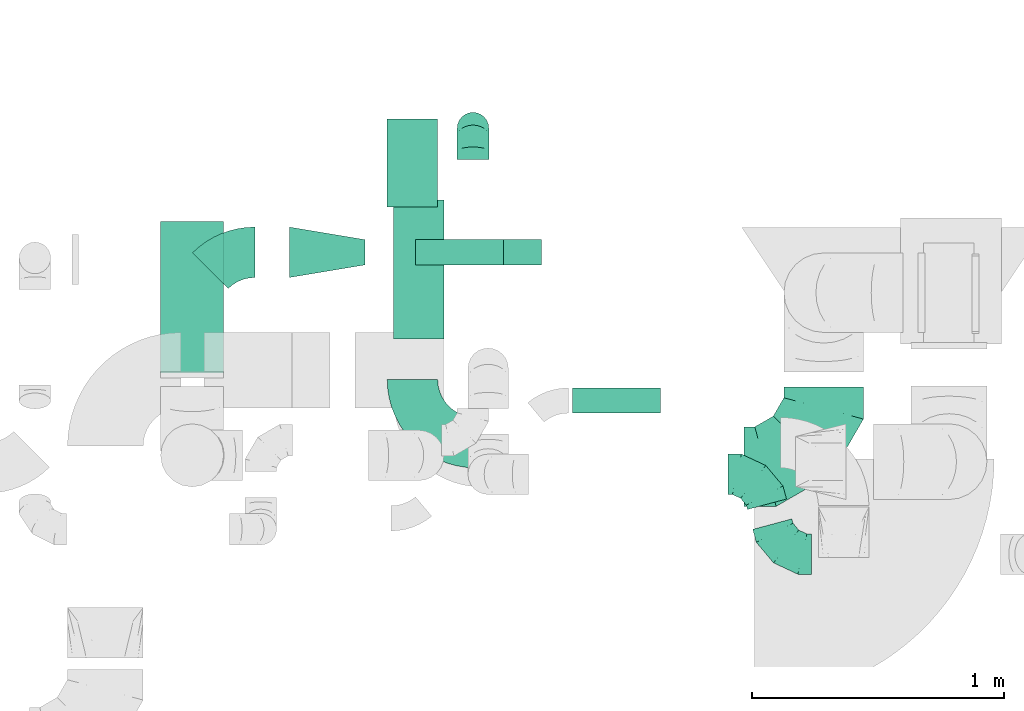
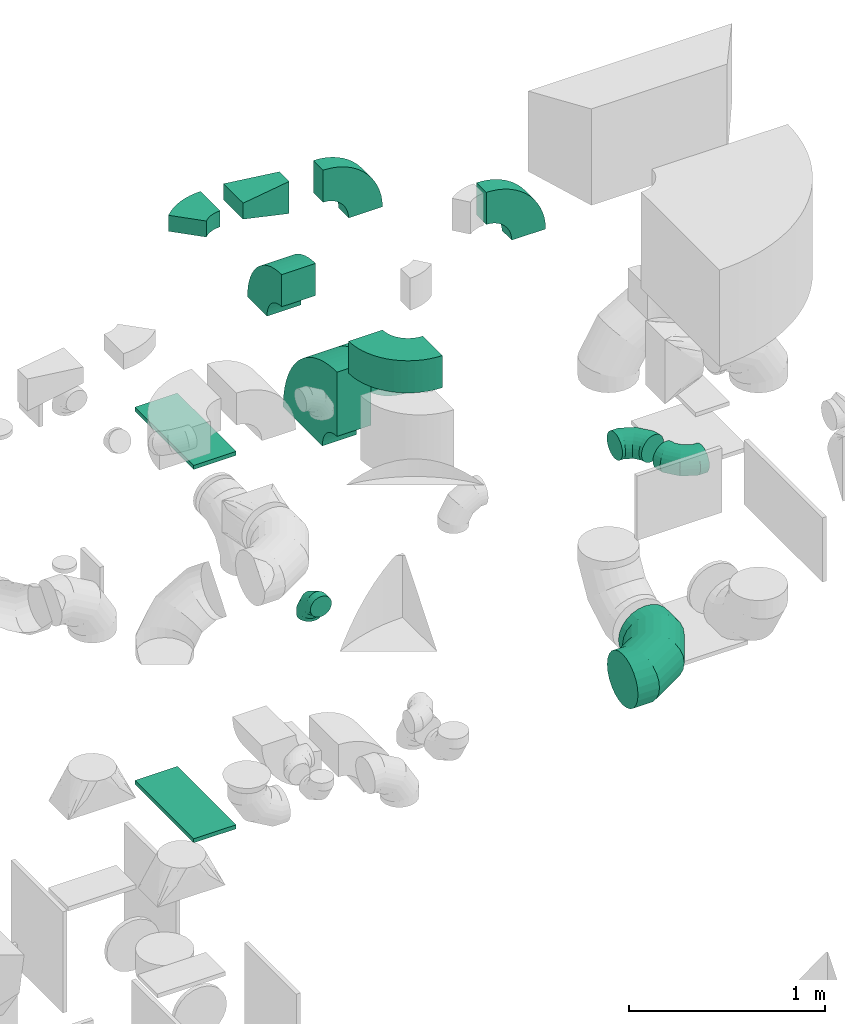
# One storey, part 31 of 59: 14 flow fittings.
"""IFC2X3 building model written with IfcOpenShell, lengths in millimetres."""

from ifc_helpers import new_model, entity, si_unit, converted_unit, derived_unit, direction, frame, frame_2d, origin, origin_2d_with_axis, place, context, subcontext, project, spatial, polyline, circle_curve, parameter, trimmed, segment, composite_curve, rectangle, outline, extrude, faceted_brep, source, transform, mapped, material, type_object, type_shapes, element, save


model = new_model("IFC2X3")

# Units and contexts
model_context = context("Model", 3, precision=0.01, world=origin(), true_north=direction((6.12303176911189e-17, 1.0)))
body_context = subcontext(model_context, "Body", "Model", "MODEL_VIEW")
ifc_project = project(units=[si_unit("LENGTHUNIT", "METRE", prefix="MILLI"), si_unit("AREAUNIT", "SQUARE_METRE"), si_unit("VOLUMEUNIT", "CUBIC_METRE"), converted_unit("PLANEANGLEUNIT", "DEGREE", entity("IfcRatioMeasure", 0.0174532925199433), si_unit("PLANEANGLEUNIT", "RADIAN"), dimensions=[0, 0, 0, 0, 0, 0, 0]), si_unit("MASSUNIT", "GRAM", prefix="KILO"), derived_unit("MASSDENSITYUNIT", [(si_unit("MASSUNIT", "GRAM", prefix="KILO"), 1), (si_unit("LENGTHUNIT", "METRE"), -3)]), derived_unit("MOMENTOFINERTIAUNIT", [(si_unit("LENGTHUNIT", "METRE"), 4)]), si_unit("TIMEUNIT", "SECOND"), si_unit("FREQUENCYUNIT", "HERTZ"), si_unit("THERMODYNAMICTEMPERATUREUNIT", "DEGREE_CELSIUS"), derived_unit("THERMALTRANSMITTANCEUNIT", [(si_unit("MASSUNIT", "GRAM", prefix="KILO"), 1), (si_unit("THERMODYNAMICTEMPERATUREUNIT", "KELVIN"), -1), (si_unit("TIMEUNIT", "SECOND"), -3)]), derived_unit("VOLUMETRICFLOWRATEUNIT", [(si_unit("LENGTHUNIT", "METRE"), 3), (si_unit("TIMEUNIT", "SECOND"), -1)]), derived_unit("MASSFLOWRATEUNIT", [(si_unit("MASSUNIT", "GRAM", prefix="KILO"), 1), (si_unit("TIMEUNIT", "SECOND"), -1)]), derived_unit("ROTATIONALFREQUENCYUNIT", [(si_unit("TIMEUNIT", "SECOND"), -1)]), si_unit("ELECTRICCURRENTUNIT", "AMPERE"), si_unit("ELECTRICVOLTAGEUNIT", "VOLT"), si_unit("POWERUNIT", "WATT"), si_unit("FORCEUNIT", "NEWTON", prefix="KILO"), si_unit("ILLUMINANCEUNIT", "LUX"), si_unit("LUMINOUSFLUXUNIT", "LUMEN"), si_unit("LUMINOUSINTENSITYUNIT", "CANDELA"), derived_unit("USERDEFINED", [(si_unit("MASSUNIT", "GRAM", prefix="KILO"), -1), (si_unit("LENGTHUNIT", "METRE"), -2), (si_unit("TIMEUNIT", "SECOND"), 3), (si_unit("LUMINOUSFLUXUNIT", "LUMEN"), 1)]), derived_unit("LINEARVELOCITYUNIT", [(si_unit("LENGTHUNIT", "METRE"), 1), (si_unit("TIMEUNIT", "SECOND"), -1)]), si_unit("PRESSUREUNIT", "PASCAL"), derived_unit("USERDEFINED", [(si_unit("LENGTHUNIT", "METRE"), -2), (si_unit("MASSUNIT", "GRAM", prefix="KILO"), 1), (si_unit("TIMEUNIT", "SECOND"), -2)]), derived_unit("LINEARFORCEUNIT", [(si_unit("MASSUNIT", "GRAM", prefix="KILO"), 1), (si_unit("LENGTHUNIT", "METRE"), 1), (si_unit("TIMEUNIT", "SECOND"), -2), (si_unit("LENGTHUNIT", "METRE"), -1)]), derived_unit("PLANARFORCEUNIT", [(si_unit("MASSUNIT", "GRAM", prefix="KILO"), 1), (si_unit("LENGTHUNIT", "METRE"), 1), (si_unit("TIMEUNIT", "SECOND"), -2), (si_unit("LENGTHUNIT", "METRE"), -2)])], contexts=[model_context])

# Site, building, storey
site_placement = place(None, origin())
site = spatial("IfcSite", under=ifc_project, at=site_placement, CompositionType="ELEMENT")
building_placement = place(site_placement, origin())
building = spatial("IfcBuilding", under=site, at=building_placement, CompositionType="ELEMENT")
storey_placement = place(building_placement, frame((0.0, 0.0, 28200.0)))
storey = spatial("IfcBuildingStorey", under=building, at=storey_placement, CompositionType="ELEMENT", Elevation=28200.0)

# Flow fittings
ifc_material = material()
duct_fitting_type_1 = type_object("IfcDuctFittingType", PredefinedType="NOTDEFINED", material=ifc_material)
shared_shape_1 = source(origin(), body_context, "Body", "SweptSolid", [
    extrude(rectangle(XDim=24.9999999999999, YDim=600.0, at=origin_2d_with_axis()), frame((12.5, 0.0, -125.0)), (0.0, 0.0, 1.0), 250.0),
])
type_shapes(duct_fitting_type_1, [shared_shape_1])
for number, where, z_axis, x_axis in (
    (1, (50893.68, 12874.75, 200.0), (1.0, 0.0, 0.0), (0.0, 0.0, -1.0)),
    (2, (50893.68, 12874.75, 2500.0), (1.0, 0.0, 0.0), (0.0, 0.0, 1.0)),
):
    element("IfcFlowFitting", number, at=place(storey_placement, frame(where, z_axis=z_axis, x_axis=x_axis)), inside=storey, type_object=duct_fitting_type_1, material=ifc_material, context=body_context, shape_type="MappedRepresentation", body=[
        mapped(shared_shape_1, transform((0.0, 0.0, 0.0), scale=1.0)),
    ])
duct_fitting_type_2 = type_object("IfcDuctFittingType", PredefinedType="NOTDEFINED", material=ifc_material)
shared_shape_2 = source(origin(), body_context, "Body", "Brep", [
    faceted_brep([(-125.0, 0.0, -62.5), (-125.0, -16.18, -60.37), (-125.0, -31.25, -54.13), (-125.0, -44.19, -44.19), (-125.0, -54.13, -31.25), (-125.0, -60.37, -16.18), (-125.0, -62.5, 0.0), (-125.0, -60.37, 16.18), (-125.0, -54.13, 31.25), (-125.0, -44.19, 44.19), (-125.0, -31.25, 54.13), (-125.0, -16.18, 60.37), (-125.0, 0.0, 62.5), (-125.0, 16.18, 60.37), (-125.0, 31.25, 54.13), (-125.0, 44.19, 44.19), (-125.0, 54.13, 31.25), (-125.0, 60.37, 16.18), (-125.0, 62.5, 0.0), (-125.0, 60.37, -16.18), (-125.0, 54.13, -31.25), (-125.0, 44.19, -44.19), (-125.0, 31.25, -54.13), (-125.0, 16.18, -60.37), (-95.84, 16.18, 60.37), (-99.88, 31.25, 54.13), (-91.51, 0.0, 62.5), (-103.35, 44.19, 44.19), (-107.68, 60.37, 16.18), (-108.25, 62.5, 0.0), (-106.01, 54.13, 31.25), (-106.01, 54.13, -31.25), (-103.35, 44.19, -44.19), (-107.68, 60.37, -16.18), (-95.84, 16.18, -60.37), (-91.51, 0.0, -62.5), (-99.88, 31.25, -54.13), (-87.17, -16.18, -60.37), (-83.13, -31.25, -54.13), (-79.66, -44.19, -44.19), (-77.0, -54.13, -31.25), (-75.33, -60.37, -16.18), (-74.76, -62.5, 0.0), (-75.33, -60.37, 16.18), (-77.0, -54.13, 31.25), (-79.66, -44.19, 44.19), (-83.13, -31.25, 54.13), (-87.17, -16.18, 60.37), (-45.34, 45.34, 60.37), (-56.37, 56.37, 54.13), (-33.49, 33.49, 62.5), (-65.85, 65.85, 44.19), (-73.12, 73.12, 31.25), (-77.69, 77.69, 16.18), (-79.25, 79.25, 0.0), (-77.69, 77.69, -16.18), (-73.12, 73.12, -31.25), (-65.85, 65.85, -44.19), (-45.34, 45.34, -60.37), (-33.49, 33.49, -62.5), (-56.37, 56.37, -54.13), (-21.65, 21.65, -60.37), (-10.62, 10.62, -54.13), (-1.14, 1.14, -44.19), (6.13, -6.13, -31.25), (10.7, -10.7, -16.18), (12.26, -12.26, 0.0), (10.7, -10.7, 16.18), (6.13, -6.13, 31.25), (-1.14, 1.14, 44.19), (-10.62, 10.62, 54.13), (-21.65, 21.65, 60.37), (-16.18, 95.84, 60.37), (-31.25, 99.88, 54.13), (0.0, 91.51, 62.5), (-44.19, 103.35, 44.19), (-54.13, 106.01, 31.25), (-60.37, 107.68, 16.18), (-62.5, 108.25, 0.0), (-60.37, 107.68, -16.18), (-54.13, 106.01, -31.25), (-44.19, 103.35, -44.19), (-16.18, 95.84, -60.37), (0.0, 91.51, -62.5), (-31.25, 99.88, -54.13), (16.18, 87.17, -60.37), (31.25, 83.13, -54.13), (44.19, 79.66, -44.19), (54.13, 77.0, -31.25), (60.37, 75.33, -16.18), (62.5, 74.76, 0.0), (60.37, 75.33, 16.18), (54.13, 77.0, 31.25), (44.19, 79.66, 44.19), (31.25, 83.13, 54.13), (16.18, 87.17, 60.37), (-16.18, 125.0, -60.37), (-31.25, 125.0, -54.13), (-44.19, 125.0, -44.19), (-54.13, 125.0, -31.25), (-60.37, 125.0, -16.18), (-62.5, 125.0, 0.0), (-60.37, 125.0, 16.18), (-54.13, 125.0, 31.25), (-44.19, 125.0, 44.19), (-31.25, 125.0, 54.13), (-16.18, 125.0, 60.37), (0.0, 125.0, 62.5), (16.18, 125.0, 60.37), (31.25, 125.0, 54.13), (44.19, 125.0, 44.19), (54.13, 125.0, 31.25), (60.37, 125.0, 16.18), (62.5, 125.0, 0.0), (60.37, 125.0, -16.18), (54.13, 125.0, -31.25), (44.19, 125.0, -44.19), (31.25, 125.0, -54.13), (16.18, 125.0, -60.37), (0.0, 125.0, -62.5)], [[[0, 1, 2, 3, 4, 5, 6, 7, 8, 9, 10, 11, 12, 13, 14, 15, 16, 17, 18, 19, 20, 21, 22, 23]], [[24, 25, 14, 13]], [[26, 24, 13, 12]], [[14, 25, 27, 15]], [[28, 29, 18, 17]], [[30, 28, 17, 16]], [[15, 27, 30, 16]], [[20, 31, 32, 21]], [[33, 31, 20, 19]], [[18, 29, 33, 19]], [[34, 35, 0, 23]], [[36, 34, 23, 22]], [[21, 32, 36, 22]], [[1, 0, 35, 37]], [[2, 1, 37, 38]], [[38, 39, 3, 2]], [[5, 4, 40, 41]], [[6, 5, 41, 42]], [[39, 40, 4, 3]], [[6, 42, 43, 7]], [[7, 43, 44, 8]], [[45, 9, 8, 44]], [[9, 45, 46, 10]], [[10, 46, 47, 11]], [[26, 12, 11, 47]], [[48, 49, 25, 24]], [[50, 48, 24, 26]], [[27, 25, 49, 51]], [[52, 53, 28, 30]], [[51, 52, 30, 27]], [[29, 28, 53, 54]], [[55, 56, 31, 33]], [[54, 55, 33, 29]], [[57, 32, 31, 56]], [[58, 59, 35, 34]], [[60, 58, 34, 36]], [[57, 60, 36, 32]], [[37, 35, 59, 61]], [[38, 37, 61, 62]], [[39, 38, 62, 63]], [[41, 40, 64, 65]], [[42, 41, 65, 66]], [[63, 64, 40, 39]], [[43, 42, 66, 67]], [[44, 43, 67, 68]], [[68, 69, 45, 44]], [[46, 45, 69, 70]], [[47, 46, 70, 71]], [[26, 47, 71, 50]], [[72, 73, 49, 48]], [[74, 72, 48, 50]], [[51, 49, 73, 75]], [[76, 77, 53, 52]], [[75, 76, 52, 51]], [[54, 53, 77, 78]], [[79, 80, 56, 55]], [[78, 79, 55, 54]], [[81, 57, 56, 80]], [[82, 83, 59, 58]], [[84, 82, 58, 60]], [[81, 84, 60, 57]], [[61, 59, 83, 85]], [[62, 61, 85, 86]], [[63, 62, 86, 87]], [[65, 64, 88, 89]], [[66, 65, 89, 90]], [[87, 88, 64, 63]], [[67, 66, 90, 91]], [[68, 67, 91, 92]], [[92, 93, 69, 68]], [[70, 69, 93, 94]], [[71, 70, 94, 95]], [[50, 71, 95, 74]], [[96, 97, 98, 99, 100, 101, 102, 103, 104, 105, 106, 107, 108, 109, 110, 111, 112, 113, 114, 115, 116, 117, 118, 119]], [[72, 74, 107, 106]], [[73, 72, 106, 105]], [[75, 73, 105, 104]], [[77, 76, 103, 102]], [[78, 77, 102, 101]], [[75, 104, 103, 76]], [[78, 101, 100, 79]], [[79, 100, 99, 80]], [[80, 99, 98, 81]], [[96, 119, 83, 82]], [[97, 96, 82, 84]], [[84, 81, 98, 97]], [[83, 119, 118, 85]], [[85, 118, 117, 86]], [[116, 87, 86, 117]], [[88, 115, 114, 89]], [[89, 114, 113, 90]], [[115, 88, 87, 116]], [[91, 90, 113, 112]], [[92, 91, 112, 111]], [[111, 110, 93, 92]], [[95, 94, 109, 108]], [[74, 95, 108, 107]], [[110, 109, 94, 93]]]),
])
type_shapes(duct_fitting_type_2, [shared_shape_2])
flow_fitting_1_placement = place(storey_placement, frame((52006.4, 13545.35, 700.0), z_axis=(-0.999999951496755, 0.000311458642587743, -4.73472009467966e-08), x_axis=(0.000311458642587743, 0.999999951496756, 0.0)))
element("IfcFlowFitting", 3, at=flow_fitting_1_placement, inside=storey, type_object=duct_fitting_type_2, material=ifc_material, context=body_context, shape_type="MappedRepresentation", body=[
    mapped(shared_shape_2, transform((0.0, 0.0, 0.0), scale=1.0)),
])
duct_fitting_type_3 = type_object("IfcDuctFittingType", PredefinedType="NOTDEFINED", material=ifc_material)
shared_shape_3 = source(origin(), body_context, "Body", "Brep", [
    faceted_brep([(-315.0, 0.0, -157.5), (-315.0, -40.76, -152.13), (-315.0, -78.75, -136.4), (-315.0, -111.37, -111.37), (-315.0, -136.4, -78.75), (-315.0, -152.13, -40.76), (-315.0, -157.5, 0.0), (-315.0, -152.13, 40.76), (-315.0, -136.4, 78.75), (-315.0, -111.37, 111.37), (-315.0, -78.75, 136.4), (-315.0, -40.76, 152.13), (-315.0, 0.0, 157.5), (-315.0, 40.76, 152.13), (-315.0, 78.75, 136.4), (-315.0, 111.37, 111.37), (-315.0, 136.4, 78.75), (-315.0, 152.13, 40.76), (-315.0, 157.5, 0.0), (-315.0, 152.13, -40.76), (-315.0, 136.4, -78.75), (-315.0, 111.37, -111.37), (-315.0, 78.75, -136.4), (-315.0, 40.76, -152.13), (-241.52, 40.76, 152.13), (-251.7, 78.75, 136.4), (-230.6, 0.0, 157.5), (-260.44, 111.37, 111.37), (-271.36, 152.13, 40.76), (-272.8, 157.5, 0.0), (-267.14, 136.4, 78.75), (-267.14, 136.4, -78.75), (-260.44, 111.37, -111.37), (-271.36, 152.13, -40.76), (-241.52, 40.76, -152.13), (-230.6, 0.0, -157.5), (-251.7, 78.75, -136.4), (-219.67, -40.76, -152.13), (-209.5, -78.75, -136.4), (-200.75, -111.37, -111.37), (-194.05, -136.4, -78.75), (-189.83, -152.13, -40.76), (-188.39, -157.5, 0.0), (-189.83, -152.13, 40.76), (-194.05, -136.4, 78.75), (-200.75, -111.37, 111.37), (-209.5, -78.75, 136.4), (-219.67, -40.76, 152.13), (-114.25, 114.25, 152.13), (-142.05, 142.05, 136.4), (-84.4, 84.4, 157.5), (-165.93, 165.93, 111.37), (-184.25, 184.25, 78.75), (-195.77, 195.77, 40.76), (-199.7, 199.7, 0.0), (-195.77, 195.77, -40.76), (-184.25, 184.25, -78.75), (-165.93, 165.93, -111.37), (-114.25, 114.25, -152.13), (-84.4, 84.4, -157.5), (-142.05, 142.05, -136.4), (-54.56, 54.56, -152.13), (-26.75, 26.75, -136.4), (-2.88, 2.88, -111.37), (15.45, -15.45, -78.75), (26.97, -26.97, -40.76), (30.89, -30.89, 0.0), (26.97, -26.97, 40.76), (15.45, -15.45, 78.75), (-2.88, 2.88, 111.37), (-26.75, 26.75, 136.4), (-54.56, 54.56, 152.13), (-40.76, 241.52, 152.13), (-78.75, 251.7, 136.4), (0.0, 230.6, 157.5), (-111.37, 260.44, 111.37), (-136.4, 267.14, 78.75), (-152.13, 271.36, 40.76), (-157.5, 272.8, 0.0), (-152.13, 271.36, -40.76), (-136.4, 267.14, -78.75), (-111.37, 260.44, -111.37), (-40.76, 241.52, -152.13), (0.0, 230.6, -157.5), (-78.75, 251.7, -136.4), (40.76, 219.67, -152.13), (78.75, 209.5, -136.4), (111.37, 200.75, -111.37), (136.4, 194.05, -78.75), (152.13, 189.83, -40.76), (157.5, 188.39, 0.0), (152.13, 189.83, 40.76), (136.4, 194.05, 78.75), (111.37, 200.75, 111.37), (78.75, 209.5, 136.4), (40.76, 219.67, 152.13), (-40.76, 315.0, -152.13), (-78.75, 315.0, -136.4), (-111.37, 315.0, -111.37), (-136.4, 315.0, -78.75), (-152.13, 315.0, -40.76), (-157.5, 315.0, 0.0), (-152.13, 315.0, 40.76), (-136.4, 315.0, 78.75), (-111.37, 315.0, 111.37), (-78.75, 315.0, 136.4), (-40.76, 315.0, 152.13), (0.0, 315.0, 157.5), (40.76, 315.0, 152.13), (78.75, 315.0, 136.4), (111.37, 315.0, 111.37), (136.4, 315.0, 78.75), (152.13, 315.0, 40.76), (157.5, 315.0, 0.0), (152.13, 315.0, -40.76), (136.4, 315.0, -78.75), (111.37, 315.0, -111.37), (78.75, 315.0, -136.4), (40.76, 315.0, -152.13), (0.0, 315.0, -157.5)], [[[0, 1, 2, 3, 4, 5, 6, 7, 8, 9, 10, 11, 12, 13, 14, 15, 16, 17, 18, 19, 20, 21, 22, 23]], [[24, 25, 14, 13]], [[26, 24, 13, 12]], [[14, 25, 27, 15]], [[28, 29, 18, 17]], [[30, 28, 17, 16]], [[15, 27, 30, 16]], [[20, 31, 32, 21]], [[33, 31, 20, 19]], [[18, 29, 33, 19]], [[34, 35, 0, 23]], [[36, 34, 23, 22]], [[32, 36, 22, 21]], [[1, 0, 35, 37]], [[2, 1, 37, 38]], [[38, 39, 3, 2]], [[5, 4, 40, 41]], [[6, 5, 41, 42]], [[39, 40, 4, 3]], [[6, 42, 43, 7]], [[7, 43, 44, 8]], [[8, 44, 45, 9]], [[9, 45, 46, 10]], [[10, 46, 47, 11]], [[26, 12, 11, 47]], [[48, 49, 25, 24]], [[50, 48, 24, 26]], [[27, 25, 49, 51]], [[52, 53, 28, 30]], [[51, 52, 30, 27]], [[29, 28, 53, 54]], [[55, 56, 31, 33]], [[54, 55, 33, 29]], [[32, 31, 56, 57]], [[58, 59, 35, 34]], [[60, 58, 34, 36]], [[57, 60, 36, 32]], [[37, 35, 59, 61]], [[38, 37, 61, 62]], [[39, 38, 62, 63]], [[41, 40, 64, 65]], [[42, 41, 65, 66]], [[63, 64, 40, 39]], [[43, 42, 66, 67]], [[44, 43, 67, 68]], [[68, 69, 45, 44]], [[46, 45, 69, 70]], [[47, 46, 70, 71]], [[26, 47, 71, 50]], [[72, 73, 49, 48]], [[74, 72, 48, 50]], [[51, 49, 73, 75]], [[76, 77, 53, 52]], [[75, 76, 52, 51]], [[54, 53, 77, 78]], [[79, 80, 56, 55]], [[78, 79, 55, 54]], [[57, 56, 80, 81]], [[82, 83, 59, 58]], [[84, 82, 58, 60]], [[81, 84, 60, 57]], [[61, 59, 83, 85]], [[62, 61, 85, 86]], [[63, 62, 86, 87]], [[65, 64, 88, 89]], [[66, 65, 89, 90]], [[87, 88, 64, 63]], [[67, 66, 90, 91]], [[68, 67, 91, 92]], [[92, 93, 69, 68]], [[70, 69, 93, 94]], [[71, 70, 94, 95]], [[50, 71, 95, 74]], [[96, 97, 98, 99, 100, 101, 102, 103, 104, 105, 106, 107, 108, 109, 110, 111, 112, 113, 114, 115, 116, 117, 118, 119]], [[106, 105, 73, 72]], [[107, 106, 72, 74]], [[75, 73, 105, 104]], [[77, 76, 103, 102]], [[78, 77, 102, 101]], [[104, 103, 76, 75]], [[78, 101, 100, 79]], [[79, 100, 99, 80]], [[98, 81, 80, 99]], [[84, 97, 96, 82]], [[82, 96, 119, 83]], [[97, 84, 81, 98]], [[83, 119, 118, 85]], [[85, 118, 117, 86]], [[116, 87, 86, 117]], [[88, 115, 114, 89]], [[89, 114, 113, 90]], [[115, 88, 87, 116]], [[91, 90, 113, 112]], [[92, 91, 112, 111]], [[111, 110, 93, 92]], [[95, 94, 109, 108]], [[74, 95, 108, 107]], [[110, 109, 94, 93]]]),
])
type_shapes(duct_fitting_type_3, [shared_shape_3])
flow_fitting_2_placement = place(storey_placement, frame((53395.67, 12204.45, 607.5)))
element("IfcFlowFitting", 4, at=flow_fitting_2_placement, inside=storey, type_object=duct_fitting_type_3, material=ifc_material, context=body_context, shape_type="MappedRepresentation", body=[
    mapped(shared_shape_3, transform((0.0, 0.0, 0.0), scale=1.0)),
])
duct_fitting_type_4 = type_object("IfcDuctFittingType", PredefinedType="NOTDEFINED", material=ifc_material)
shared_shape_4 = source(origin(), body_context, "Body", "Brep", [
    faceted_brep([(-122.77, 0.0, -80.0), (-122.77, -20.71, -77.27), (-122.77, -40.0, -69.28), (-122.77, -56.57, -56.57), (-122.77, -69.28, -40.0), (-122.77, -77.27, -20.71), (-122.77, -80.0, 0.0), (-122.77, -77.27, 20.71), (-122.77, -69.28, 40.0), (-122.77, -56.57, 56.57), (-122.77, -40.0, 69.28), (-122.77, -20.71, 77.27), (-122.77, 0.0, 80.0), (-122.77, 20.71, 77.27), (-122.77, 40.0, 69.28), (-122.77, 56.57, 56.57), (-122.77, 69.28, 40.0), (-122.77, 77.27, 20.71), (-122.77, 80.0, 0.0), (-122.77, 77.27, -20.71), (-122.77, 69.28, -40.0), (-122.77, 56.57, -56.57), (-122.77, 40.0, -69.28), (-122.77, 20.71, -77.27), (-91.89, 20.71, 77.27), (-96.17, 40.0, 69.28), (-87.3, 0.0, 80.0), (-99.84, 56.57, 56.57), (-104.43, 77.27, 20.71), (-105.04, 80.0, 0.0), (-102.66, 69.28, 40.0), (-102.66, 69.28, -40.0), (-99.84, 56.57, -56.57), (-104.43, 77.27, -20.71), (-91.89, 20.71, -77.27), (-87.3, 0.0, -80.0), (-96.17, 40.0, -69.28), (-82.71, -20.71, -77.27), (-78.43, -40.0, -69.28), (-74.76, -56.57, -56.57), (-71.94, -69.28, -40.0), (-70.17, -77.27, -20.71), (-69.57, -80.0, 0.0), (-70.17, -77.27, 20.71), (-71.94, -69.28, 40.0), (-74.76, -56.57, 56.57), (-78.43, -40.0, 69.28), (-82.71, -20.71, 77.27), (-35.92, 46.81, 77.27), (-47.95, 62.49, 69.28), (-23.01, 29.98, 80.0), (-58.28, 75.95, 56.57), (-66.21, 86.28, 40.0), (-71.19, 92.78, 20.71), (-72.89, 94.99, 0.0), (-71.19, 92.78, -20.71), (-66.21, 86.28, -40.0), (-58.28, 75.95, -56.57), (-35.92, 46.81, -77.27), (-23.01, 29.98, -80.0), (-47.95, 62.49, -69.28), (-10.09, 13.16, -77.27), (1.94, -2.52, -69.28), (12.27, -15.99, -56.57), (20.19, -26.32, -40.0), (25.18, -32.81, -20.71), (26.88, -35.03, 0.0), (25.18, -32.81, 20.71), (20.19, -26.32, 40.0), (12.27, -15.99, 56.57), (1.94, -2.52, 69.28), (-10.09, 13.16, 77.27), (3.78, 94.12, 77.27), (-13.75, 103.24, 69.28), (22.6, 84.33, 80.0), (-28.8, 111.08, 56.57), (-40.35, 117.09, 40.0), (-47.61, 120.87, 20.71), (-50.09, 122.16, 0.0), (-47.61, 120.87, -20.71), (-40.35, 117.09, -40.0), (-28.8, 111.08, -56.57), (3.78, 94.12, -77.27), (22.6, 84.33, -80.0), (-13.75, 103.24, -69.28), (41.41, 74.53, -77.27), (58.94, 65.41, -69.28), (73.99, 57.57, -56.57), (85.54, 51.56, -40.0), (92.8, 47.78, -20.71), (95.28, 46.49, 0.0), (92.8, 47.78, 20.71), (85.54, 51.56, 40.0), (73.99, 57.57, 56.57), (58.94, 65.41, 69.28), (41.41, 74.53, 77.27), (11.78, 123.95, -77.27), (-6.86, 128.94, -69.28), (-22.87, 133.23, -56.57), (-35.15, 136.52, -40.0), (-42.87, 138.59, -20.71), (-45.5, 139.29, 0.0), (-42.87, 138.59, 20.71), (-35.15, 136.52, 40.0), (-22.87, 133.23, 56.57), (-6.86, 128.94, 69.28), (11.78, 123.95, 77.27), (31.78, 118.59, 80.0), (51.78, 113.23, 77.27), (70.41, 108.24, 69.28), (86.42, 103.95, 56.57), (98.7, 100.66, 40.0), (106.42, 98.59, 20.71), (109.05, 97.88, 0.0), (106.42, 98.59, -20.71), (98.7, 100.66, -40.0), (86.42, 103.95, -56.57), (70.41, 108.24, -69.28), (51.78, 113.23, -77.27), (31.78, 118.59, -80.0)], [[[0, 1, 2, 3, 4, 5, 6, 7, 8, 9, 10, 11, 12, 13, 14, 15, 16, 17, 18, 19, 20, 21, 22, 23]], [[24, 25, 14, 13]], [[26, 24, 13, 12]], [[14, 25, 27, 15]], [[28, 29, 18, 17]], [[30, 28, 17, 16]], [[15, 27, 30, 16]], [[20, 31, 32, 21]], [[33, 31, 20, 19]], [[18, 29, 33, 19]], [[34, 35, 0, 23]], [[36, 34, 23, 22]], [[32, 36, 22, 21]], [[2, 1, 37, 38]], [[3, 2, 38, 39]], [[0, 35, 37, 1]], [[5, 4, 40, 41]], [[6, 5, 41, 42]], [[39, 40, 4, 3]], [[6, 42, 43, 7]], [[7, 43, 44, 8]], [[8, 44, 45, 9]], [[10, 46, 47, 11]], [[11, 47, 26, 12]], [[9, 45, 46, 10]], [[48, 49, 25, 24]], [[50, 48, 24, 26]], [[27, 25, 49, 51]], [[52, 53, 28, 30]], [[51, 52, 30, 27]], [[29, 28, 53, 54]], [[55, 56, 31, 33]], [[54, 55, 33, 29]], [[32, 31, 56, 57]], [[58, 59, 35, 34]], [[60, 58, 34, 36]], [[57, 60, 36, 32]], [[37, 35, 59, 61]], [[38, 37, 61, 62]], [[39, 38, 62, 63]], [[41, 40, 64, 65]], [[42, 41, 65, 66]], [[63, 64, 40, 39]], [[43, 42, 66, 67]], [[44, 43, 67, 68]], [[68, 69, 45, 44]], [[46, 45, 69, 70]], [[47, 46, 70, 71]], [[26, 47, 71, 50]], [[72, 73, 49, 48]], [[74, 72, 48, 50]], [[51, 49, 73, 75]], [[76, 77, 53, 52]], [[75, 76, 52, 51]], [[54, 53, 77, 78]], [[79, 80, 56, 55]], [[78, 79, 55, 54]], [[57, 56, 80, 81]], [[82, 83, 59, 58]], [[84, 82, 58, 60]], [[81, 84, 60, 57]], [[61, 59, 83, 85]], [[62, 61, 85, 86]], [[63, 62, 86, 87]], [[65, 64, 88, 89]], [[66, 65, 89, 90]], [[87, 88, 64, 63]], [[67, 66, 90, 91]], [[68, 67, 91, 92]], [[92, 93, 69, 68]], [[70, 69, 93, 94]], [[71, 70, 94, 95]], [[50, 71, 95, 74]], [[96, 97, 98, 99, 100, 101, 102, 103, 104, 105, 106, 107, 108, 109, 110, 111, 112, 113, 114, 115, 116, 117, 118, 119]], [[72, 74, 107, 106]], [[73, 72, 106, 105]], [[75, 73, 105, 104]], [[77, 76, 103, 102]], [[78, 77, 102, 101]], [[75, 104, 103, 76]], [[78, 101, 100, 79]], [[79, 100, 99, 80]], [[80, 99, 98, 81]], [[84, 97, 96, 82]], [[82, 96, 119, 83]], [[84, 81, 98, 97]], [[83, 119, 118, 85]], [[85, 118, 117, 86]], [[86, 117, 116, 87]], [[88, 115, 114, 89]], [[89, 114, 113, 90]], [[87, 116, 115, 88]], [[91, 90, 113, 112]], [[92, 91, 112, 111]], [[93, 92, 111, 110]], [[95, 94, 109, 108]], [[74, 95, 108, 107]], [[110, 109, 94, 93]]]),
])
type_shapes(duct_fitting_type_4, [shared_shape_4])
for number, where, z_axis, x_axis in (
    (5, (53224.02, 11858.0, 2105.0), (0.0, 0.0, 1.0), (0.258819045102528, -0.965925826289066, 0.0)),
    (6, (53139.34, 12174.0, 2105.0), (0.0, 0.0, 1.0), (-0.258819045102477, 0.96592582628908, 0.0)),
):
    element("IfcFlowFitting", number, at=place(storey_placement, frame(where, z_axis=z_axis, x_axis=x_axis)), inside=storey, type_object=duct_fitting_type_4, material=ifc_material, context=body_context, shape_type="MappedRepresentation", body=[
        mapped(shared_shape_4, transform((0.0, 0.0, 0.0), scale=1.0)),
    ])
duct_fitting_type_5 = type_object("IfcDuctFittingType", PredefinedType="NOTDEFINED", material=ifc_material)
shared_shape_5 = source(origin(), body_context, "Body", "Brep", [
    faceted_brep([(300.0, -50.0, 50.0), (300.0, -50.0, -150.0), (300.0, 50.0, -150.0), (300.0, 50.0, 50.0), (0.0, -100.0, 50.0), (0.0, 100.0, 50.0), (0.0, 100.0, -50.0), (0.0, -100.0, -50.0)], [[[0, 1, 2, 3]], [[4, 5, 6, 7]], [[4, 7, 1, 0]], [[7, 6, 2, 1]], [[6, 5, 3, 2]], [[5, 4, 0, 3]]]),
])
type_shapes(duct_fitting_type_5, [shared_shape_5])
flow_fitting_3_placement = place(storey_placement, frame((51278.63, 13053.66, 3700.0)))
element("IfcFlowFitting", 7, at=flow_fitting_3_placement, inside=storey, type_object=duct_fitting_type_5, material=ifc_material, context=body_context, shape_type="MappedRepresentation", body=[
    mapped(shared_shape_5, transform((0.0, 0.0, 0.0), scale=1.0)),
])
duct_fitting_type_6 = type_object("IfcDuctFittingType", PredefinedType="NOTDEFINED", material=ifc_material)
shared_shape_6 = source(origin(), body_context, "Body", "SweptSolid", [
    extrude(outline(composite_curve([segment(polyline([(-375.0, -175.0), (25.0, -175.0)]), True, "CONTINUOUS"), segment(trimmed(circle_curve(frame_2d((175.0, -175.0), x_axis=(0.0, 1.0)), 150.0), [parameter(0.0)], [parameter(90.0000000000001)], True, "PARAMETER"), False, "CONTINUOUS"), segment(polyline([(175.0, -25.0), (175.0, 375.0)]), True, "CONTINUOUS"), segment(trimmed(circle_curve(frame_2d((175.0, -175.0), x_axis=(0.0, 1.0)), 550.0), [parameter(0.0)], [parameter(90.0)], True, "PARAMETER"), True, "CONTINUOUS")], self_intersect=False)), frame((-175.0, 175.0, -100.0), z_axis=(0.0, 0.0, 1.0), x_axis=(-1.0, 0.0, 0.0)), (0.0, 0.0, 1.0), 200.0),
])
type_shapes(duct_fitting_type_6, [shared_shape_6])
flow_fitting_4_placement = place(storey_placement, frame((51791.36, 13061.01, 2500.0), z_axis=(-1.0, 0.0, 0.0), x_axis=(0.0, 1.0, 0.0)))
element("IfcFlowFitting", 8, at=flow_fitting_4_placement, inside=storey, type_object=duct_fitting_type_6, material=ifc_material, context=body_context, shape_type="MappedRepresentation", body=[
    mapped(shared_shape_6, transform((0.0, 0.0, 0.0), scale=1.0)),
])
duct_fitting_type_7 = type_object("IfcDuctFittingType", PredefinedType="NOTDEFINED", material=ifc_material)
shared_shape_7 = source(origin(), body_context, "Body", "SweptSolid", [
    extrude(outline(composite_curve([segment(polyline([(-225.0, -125.0), (-25.0, -125.0)]), True, "CONTINUOUS"), segment(trimmed(circle_curve(frame_2d((125.0, -125.0), x_axis=(0.0, 1.0)), 150.0), [parameter(0.0)], [parameter(90.0)], True, "PARAMETER"), False, "CONTINUOUS"), segment(polyline([(125.0, 25.0), (125.0, 225.0)]), True, "CONTINUOUS"), segment(trimmed(circle_curve(frame_2d((125.0, -125.0), x_axis=(0.0, 1.0)), 350.0), [parameter(0.0)], [parameter(90.0)], True, "PARAMETER"), True, "CONTINUOUS")], self_intersect=False)), frame((-125.0, 125.0, -100.0), z_axis=(0.0, 0.0, 1.0), x_axis=(-1.0, 0.0, 0.0)), (0.0, 0.0, 1.0), 200.0),
])
type_shapes(duct_fitting_type_7, [shared_shape_7])
for number, where, z_axis, x_axis in (
    (9, (51766.52, 13482.59, 2900.0), (1.0, 0.0, 0.0), (0.0, 0.0, 1.0)),
    (10, (51766.52, 12299.6, 2900.0), (-9.55759822300622e-08, 0.0, 1.0), (0.0, -1.0, 0.0)),
):
    element("IfcFlowFitting", number, at=place(storey_placement, frame(where, z_axis=z_axis, x_axis=x_axis)), inside=storey, type_object=duct_fitting_type_7, material=ifc_material, context=body_context, shape_type="MappedRepresentation", body=[
        mapped(shared_shape_7, transform((0.0, 0.0, 0.0), scale=1.0)),
    ])
duct_fitting_type_8 = type_object("IfcDuctFittingType", PredefinedType="NOTDEFINED", material=ifc_material)
shared_shape_8 = source(origin(), body_context, "Body", "SweptSolid", [
    extrude(outline(composite_curve([segment(polyline([(-225.0, -125.0), (-25.0, -125.0)]), True, "CONTINUOUS"), segment(trimmed(circle_curve(frame_2d((125.0, -125.0), x_axis=(0.0, 1.0)), 150.0), [parameter(0.0)], [parameter(90.0000000000001)], True, "PARAMETER"), False, "CONTINUOUS"), segment(polyline([(125.0, 25.0), (125.0, 225.0)]), True, "CONTINUOUS"), segment(trimmed(circle_curve(frame_2d((125.0, -125.0), x_axis=(0.0, 1.0)), 350.0), [parameter(0.0)], [parameter(90.0000000000001)], True, "PARAMETER"), True, "CONTINUOUS")], self_intersect=False)), frame((-125.0, 125.0, -50.0), z_axis=(0.0, 0.0, 1.0), x_axis=(-1.0, 0.0, 0.0)), (0.0, 0.0, 1.0), 100.0),
])
type_shapes(duct_fitting_type_8, [shared_shape_8])
for number, where, z_axis, x_axis in (
    (11, (52650.22, 12466.31, 3650.0), (0.0, 1.0, 0.0), (1.0, 0.0, 0.0)),
    (12, (52028.13, 13053.66, 3650.0), (0.0, 1.0, 0.0), (1.0, 0.0, 0.0)),
    (13, (52028.13, 13053.66, 2290.0), (0.0, -1.0, 0.0), (0.0, 0.0, -1.0)),
):
    element("IfcFlowFitting", number, at=place(storey_placement, frame(where, z_axis=z_axis, x_axis=x_axis)), inside=storey, type_object=duct_fitting_type_8, material=ifc_material, context=body_context, shape_type="MappedRepresentation", body=[
        mapped(shared_shape_8, transform((0.0, 0.0, 0.0), scale=1.0)),
    ])
duct_fitting_type_9 = type_object("IfcDuctFittingType", PredefinedType="NOTDEFINED", material=ifc_material)
shared_shape_9 = source(origin(), body_context, "Body", "SweptSolid", [
    extrude(outline(composite_curve([segment(polyline([(-136.61, -88.39), (63.39, -88.39)]), True, "CONTINUOUS"), segment(trimmed(circle_curve(frame_2d((213.39, -88.39), x_axis=(-0.707106781186546, 0.707106781186546)), 150.0), [parameter(0.0)], [parameter(45.0)], True, "PARAMETER"), False, "CONTINUOUS"), segment(polyline([(107.32, 17.68), (-34.1, 159.1)]), True, "CONTINUOUS"), segment(trimmed(circle_curve(frame_2d((213.39, -88.39), x_axis=(-0.707106781186546, 0.707106781186546)), 350.0), [parameter(0.0)], [parameter(45.0)], True, "PARAMETER"), True, "CONTINUOUS")], self_intersect=False)), frame((-15.17, 36.61, -50.0), z_axis=(0.0, 0.0, 1.0), x_axis=(-0.707106781186547, 0.707106781186548, 0.0)), (0.0, 0.0, 1.0), 100.0),
])
type_shapes(duct_fitting_type_9, [shared_shape_9])
flow_fitting_5_placement = place(storey_placement, frame((51038.79, 13053.66, 3700.0), z_axis=(0.0, -2.4600868274678e-08, 1.0), x_axis=(-1.0, 0.0, 0.0)))
element("IfcFlowFitting", 14, at=flow_fitting_5_placement, inside=storey, type_object=duct_fitting_type_9, material=ifc_material, context=body_context, shape_type="MappedRepresentation", body=[
    mapped(shared_shape_9, transform((0.0, 0.0, 0.0), scale=1.0)),
])

save(model, "model.ifc")
